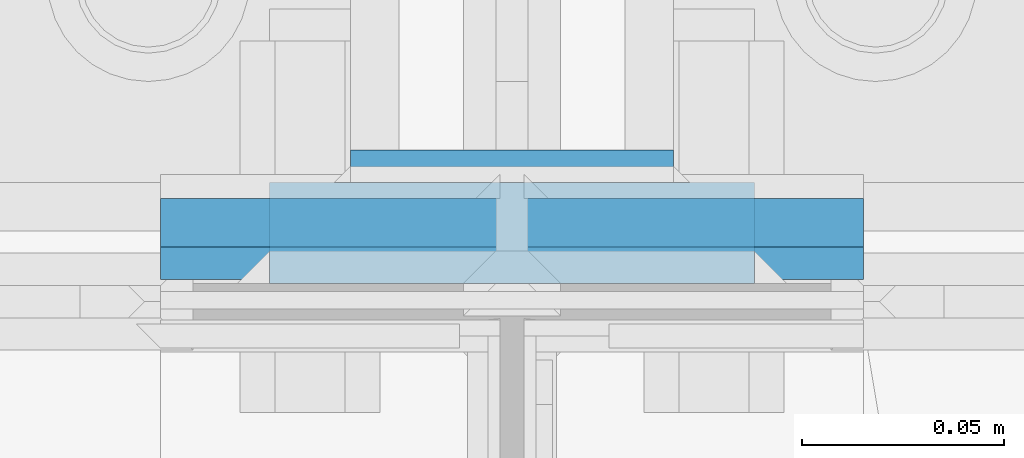
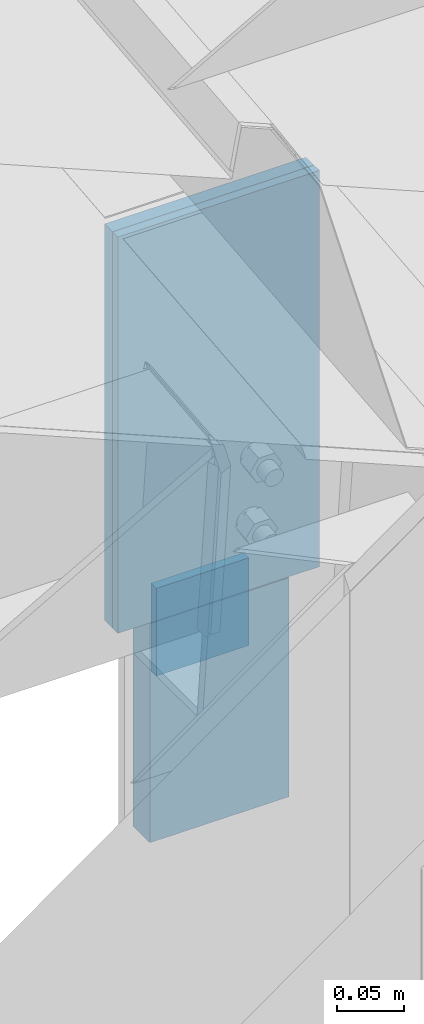
# One storey, part 20 of 709: 4 columns, 3 elements without a shape of their own.
"""IFC4 building model written with IfcOpenShell, lengths in millimetres."""

import ifcopenshell
import ifcopenshell.guid

model = None  # the IFC model being written
_history = None  # IfcOwnerHistory: only IFC2X3 demands one
_inside = {}  # id of a spatial element -> (the spatial element, [elements in it])
_under = {}  # id of a project, library or spatial element -> (it, [spatial elements below it])
_declared = {}  # id of a project -> (the project, [libraries it declares])
_typed = {}  # id of a type object -> (the type object, [elements of that type])
_made_of = {}  # id of a material, layer set ... -> (it, [elements and type objects made of it])


def new_model(schema):
    """Start an empty IFC model of exactly this schema.

    Asked for "IFC4X3", IfcOpenShell would pick the latest addendum, in which some entities
    have other attributes; the version numbers below select the first issue.
    IFC2X3 requires an IfcOwnerHistory on every rooted entity: one is made here for all.
    """
    global model, _history
    if schema == "IFC4X3":
        model = ifcopenshell.file(schema_version=(4, 3, 0, 0))
    else:
        model = ifcopenshell.file(schema=schema)
    _inside.clear()
    _under.clear()
    _declared.clear()
    _typed.clear()
    _made_of.clear()
    _history = None
    if model.schema == "IFC2X3":
        org = make("IfcOrganization", Name="unknown")
        user = make(
            "IfcPersonAndOrganization",
            ThePerson=make("IfcPerson", FamilyName="unknown"),
            TheOrganization=org,
        )
        app = make(
            "IfcApplication",
            ApplicationDeveloper=org,
            Version="unknown",
            ApplicationFullName="unknown",
            ApplicationIdentifier="unknown",
        )
        _history = make(
            "IfcOwnerHistory",
            OwningUser=user,
            OwningApplication=app,
            ChangeAction="ADDED",
            CreationDate=0,
        )
    return model


def make(cls, **values):
    """One entity of the class cls with the attributes given. An attribute that is None is left unset."""
    return model.create_entity(
        cls, **{name: value for name, value in values.items() if value is not None}
    )


def rooted(cls, **values):
    """An entity with a GlobalId (a new one), such as an element, a storey or a relation."""
    return make(cls, GlobalId=ifcopenshell.guid.new(), OwnerHistory=_history, **values)


def si_unit(unit_type, name, prefix=None):
    """IfcSIUnit, for example si_unit("LENGTHUNIT", "METRE", prefix="MILLI")."""
    return make("IfcSIUnit", UnitType=unit_type, Prefix=prefix, Name=name)


def assignment(units):
    """IfcUnitAssignment: the units of a project."""
    return None if units is None else make("IfcUnitAssignment", Units=units)


def point(xyz):
    """IfcCartesianPoint."""
    return None if xyz is None else make("IfcCartesianPoint", Coordinates=xyz)


def direction(xyz):
    """IfcDirection."""
    return None if xyz is None else make("IfcDirection", DirectionRatios=xyz)


def frame(location, z_axis=None, x_axis=None):
    """IfcAxis2Placement3D, a coordinate frame: its origin and axes. An axis left out is left unset."""
    return make(
        "IfcAxis2Placement3D",
        Location=point(location),
        Axis=direction(z_axis),
        RefDirection=direction(x_axis),
    )


def origin_with_axes():
    """The frame at (0, 0, 0) with the z axis (0, 0, 1) and the x axis (1, 0, 0) written out."""
    return frame((0.0, 0.0, 0.0), z_axis=(0.0, 0.0, 1.0), x_axis=(1.0, 0.0, 0.0))


def place(relative_to, where):
    """IfcLocalPlacement: puts the frame where relative to a parent placement (None: the world)."""
    return make(
        "IfcLocalPlacement", PlacementRelTo=relative_to, RelativePlacement=where
    )


def context(
    kind, dimensions, precision=None, world=None, true_north=None, identifier=None
):
    """IfcGeometricRepresentationContext, for example the 3D "Model" context."""
    return make(
        "IfcGeometricRepresentationContext",
        ContextIdentifier=identifier,
        ContextType=kind,
        CoordinateSpaceDimension=dimensions,
        Precision=precision,
        WorldCoordinateSystem=world,
        TrueNorth=true_north,
    )


def subcontext(parent, identifier, kind, view, scale=None):
    """IfcGeometricRepresentationSubContext, for example "Body" below "Model"."""
    return make(
        "IfcGeometricRepresentationSubContext",
        ContextIdentifier=identifier,
        ContextType=kind,
        ParentContext=parent,
        TargetScale=scale,
        TargetView=view,
    )


def project(units=None, contexts=None):
    """IfcProject with its units and contexts."""
    return rooted(
        "IfcProject",
        Name="project",
        RepresentationContexts=contexts,
        UnitsInContext=assignment(units),
    )


def spatial(cls, under=None, at=None, **own):
    """A site, building, storey or space (cls), placed at a placement, below another one or the project."""
    s = rooted(cls, ObjectPlacement=at, **own)
    if under is not None:
        _under.setdefault(under.id(), (under, []))[1].append(s)
    return s


def point_list(points):
    """IfcCartesianPointList2D or 3D."""
    cls = (
        "IfcCartesianPointList2D" if len(points[0]) == 2 else "IfcCartesianPointList3D"
    )
    return make(cls, CoordList=points)


def line(*indices):
    """IfcLineIndex: a straight run through numbered points of an indexed curve."""
    return model.create_entity("IfcLineIndex", indices)


def indexed_curve(points, segments=None, self_intersect=None):
    """IfcIndexedPolyCurve: lines and arcs through numbered points (the first is 1)."""
    return make(
        "IfcIndexedPolyCurve",
        Points=point_list(points),
        Segments=segments,
        SelfIntersect=self_intersect,
    )


def outline(outer, holes=None, kind="AREA"):
    """IfcArbitraryClosedProfileDef: a profile drawn as a closed curve; with holes, ...WithVoids."""
    if holes is None:
        return make("IfcArbitraryClosedProfileDef", ProfileType=kind, OuterCurve=outer)
    return make(
        "IfcArbitraryProfileDefWithVoids",
        ProfileType=kind,
        OuterCurve=outer,
        InnerCurves=holes,
    )


def extrude(swept, where, along, depth):
    """IfcExtrudedAreaSolid: the profile swept, set in the frame where, extruded along a direction by depth."""
    return make(
        "IfcExtrudedAreaSolid",
        SweptArea=swept,
        Position=where,
        ExtrudedDirection=direction(along),
        Depth=depth,
    )


def shape(context_of_items, identifier, shape_type, items):
    """IfcShapeRepresentation: the items that make up one representation, for example the "Body"."""
    return make(
        "IfcShapeRepresentation",
        ContextOfItems=context_of_items,
        RepresentationIdentifier=identifier,
        RepresentationType=shape_type,
        Items=items,
    )


def material(Name=None, Category=None):
    """IfcMaterial."""
    return make("IfcMaterial", Name=Name, Category=Category)


def made_of(thing, what):
    """Note that an element or type object is made of a material, layer set ...; save() writes the relation."""
    if what is not None:
        _made_of.setdefault(what.id(), (what, []))[1].append(thing)
    return thing


def element(
    cls,
    number,
    at=None,
    inside=None,
    cuts=None,
    type_object=None,
    material=None,
    context=None,
    identifier="Body",
    shape_type=None,
    held_by="IfcProductDefinitionShape",
    body=None,
    shapes=None,
    **own,
):
    """One element of the class cls, such as IfcWall. Its Tag is "e" and its number.

    at: its placement. inside: the storey or other place that contains it. cuts: it is an
    opening in that element (IfcRelVoidsElement). A single representation is given by context,
    identifier, shape_type and body (its items); several are given by shapes. held_by: the class
    of the entity that holds the representations. save() writes the other relations.
    """
    e = rooted(cls, Tag="e%d" % number, ObjectPlacement=at, **own)
    if body is not None:
        shapes = [shape(context, identifier, shape_type, body)]
    if shapes is not None:
        e.Representation = make(held_by, Representations=shapes)
    if inside is not None:
        _inside.setdefault(inside.id(), (inside, []))[1].append(e)
    if cuts is not None:
        rooted(
            "IfcRelVoidsElement", RelatingBuildingElement=cuts, RelatedOpeningElement=e
        )
    if type_object is not None:
        _typed.setdefault(type_object.id(), (type_object, []))[1].append(e)
    return made_of(e, material)


def aggregate(whole, parts):
    """IfcRelAggregates: a whole, such as a stair, and the parts it consists of."""
    return rooted("IfcRelAggregates", RelatingObject=whole, RelatedObjects=parts)


def save(model, path):
    """Write the relations noted so far, then the file.

    IfcRelAggregates (storeys below a building ...), IfcRelContainedInSpatialStructure (elements
    in a storey), IfcRelDefinesByType, IfcRelAssociatesMaterial and IfcRelDeclares: one each for
    every whole, place, type object, material and project.
    """
    for whole, parts in _under.values():
        aggregate(whole, parts)
    for where, things in _inside.values():
        rooted(
            "IfcRelContainedInSpatialStructure",
            RelatedElements=things,
            RelatingStructure=where,
        )
    for kind, things in _typed.values():
        rooted("IfcRelDefinesByType", RelatedObjects=things, RelatingType=kind)
    for what, things in _made_of.values():
        rooted("IfcRelAssociatesMaterial", RelatedObjects=things, RelatingMaterial=what)
    for by, libraries in _declared.values():
        rooted("IfcRelDeclares", RelatingContext=by, RelatedDefinitions=libraries)
    model.write(path)


model = new_model("IFC4")

# Units and contexts
model_context = context("Model", 3, precision=0.2, world=origin_with_axes(), true_north=direction((0.0, 1.0)))
body_context = subcontext(model_context, "Body", "Model", "MODEL_VIEW")
ifc_project = project(units=[si_unit("LENGTHUNIT", "METRE", prefix="MILLI"), si_unit("AREAUNIT", "SQUARE_METRE"), si_unit("VOLUMEUNIT", "CUBIC_METRE"), si_unit("MASSUNIT", "GRAM", prefix="KILO"), si_unit("TIMEUNIT", "SECOND"), si_unit("PLANEANGLEUNIT", "RADIAN"), si_unit("SOLIDANGLEUNIT", "STERADIAN"), si_unit("THERMODYNAMICTEMPERATUREUNIT", "DEGREE_CELSIUS"), si_unit("LUMINOUSINTENSITYUNIT", "LUMEN")], contexts=[model_context])

# Site, building, storey
site_placement = place(None, origin_with_axes())
site = spatial("IfcSite", under=ifc_project, at=site_placement, CompositionType="ELEMENT")
building_placement = place(site_placement, origin_with_axes())
building = spatial("IfcBuilding", under=site, at=building_placement, Name="Undefined", CompositionType="ELEMENT")
storey_placement = place(building_placement, origin_with_axes())
storey = spatial("IfcBuildingStorey", under=building, at=storey_placement, Name="Undefined", CompositionType="ELEMENT", Elevation=0.0)

# Assembly, column
assembly_1_placement = place(storey_placement, frame((28000.0, 346.0, 7089.70002), z_axis=(1.0, 0.0, 0.0), x_axis=(0.0, 0.9950371902, 0.099503719)))
assembly_1 = element("IfcElementAssembly", 1, at=assembly_1_placement, inside=storey)
ifc_material = material(Name="C355-6", Category="STEEL")
column_1_placement = place(assembly_1_placement, frame((-4.15556, -192.30372, 0.0), z_axis=(0.9950371902, -0.099503719, 0.0), x_axis=(0.099503719, 0.9950371902, 0.0)))
column_1 = element("IfcColumn", 2, at=column_1_placement, material=ifc_material, ObjectType="457", context=body_context, shape_type="SolidModel", body=[
    extrude(outline(indexed_curve([(-6.0, -87.0), (6.0, -87.0), (6.0, 87.0), (-6.0, 87.0)], segments=[line(1, 2, 3, 4, 1)])), frame((0.0, 0.0, 0.0), z_axis=(-1.0, 0.0, 0.0), x_axis=(0.0, 0.0, 1.0)), (0.0, 0.0, -1.0), 361.7257),
])
aggregate(assembly_1, [column_1])

assembly_2_placement = place(storey_placement, frame((28000.0, 351.0, 6897.93718), z_axis=(0.0, 1.0, 0.0), x_axis=(0.0, 0.0, 1.0)))
assembly_2 = element("IfcElementAssembly", 3, at=assembly_2_placement, inside=storey)
column_2_placement = place(assembly_2_placement, origin_with_axes())
column_2 = element("IfcColumn", 4, at=column_2_placement, material=ifc_material, ObjectType="458", context=body_context, shape_type="SolidModel", body=[
    extrude(outline(indexed_curve([(-4.0, -87.0), (4.0, -87.0), (4.0, 87.0), (-4.0, 87.0)], segments=[line(1, 2, 3, 4, 1)])), frame((0.0, 0.0, 0.0), z_axis=(-1.0, 0.0, 0.0), x_axis=(0.0, 0.0, 1.0)), (0.0, 0.0, -1.0), 361.7257),
])
aggregate(assembly_2, [column_2])

# Assembly, columns
assembly_3_placement = place(storey_placement, frame((28000.0, 173.0, -200.0), z_axis=(-1.0, 0.0, 0.0), x_axis=(0.0, 0.0, 1.0)))
assembly_3 = element("IfcElementAssembly", 5, at=assembly_3_placement, inside=storey)
column_3_placement = place(assembly_3_placement, frame((7027.93718, 202.0, 0.0), z_axis=(0.0, 1.0, 0.0), x_axis=(1.0, 0.0, 0.0)))
column_3 = element("IfcColumn", 6, at=column_3_placement, material=ifc_material, ObjectType="462", context=body_context, shape_type="SolidModel", body=[
    extrude(outline(indexed_curve([(-4.0, -40.0), (4.0, -40.0), (4.0, 40.0), (-4.0, 40.0)], segments=[line(1, 2, 3, 4, 1)])), frame((0.0, 0.0, 0.0), z_axis=(-1.0, 0.0, 0.0), x_axis=(0.0, 0.0, 1.0)), (0.0, 0.0, -1.0), 80.0),
])
column_4_placement = place(assembly_3_placement, frame((6897.93718, 185.5, 0.0), z_axis=(0.0, 1.0, 0.0), x_axis=(1.0, 0.0, 0.0)))
column_4 = element("IfcColumn", 7, at=column_4_placement, material=ifc_material, ObjectType="459", context=body_context, shape_type="SolidModel", body=[
    extrude(outline(indexed_curve([(-12.5, -60.0), (12.5, -60.0), (12.5, 60.0), (-12.5, 60.0)], segments=[line(1, 2, 3, 4, 1)])), frame((0.0, 0.0, 0.0), z_axis=(-1.0, 0.0, 0.0), x_axis=(0.0, 0.0, 1.0)), (0.0, 0.0, -1.0), 200.0),
])
aggregate(assembly_3, [column_3, column_4])

save(model, "model.ifc")
